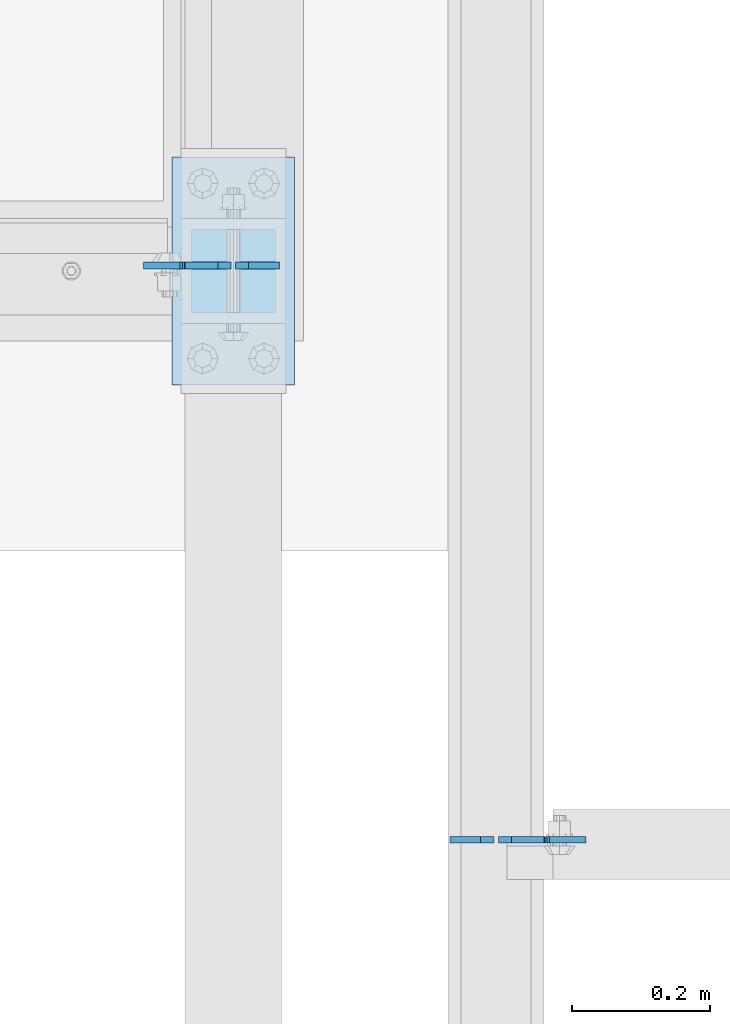
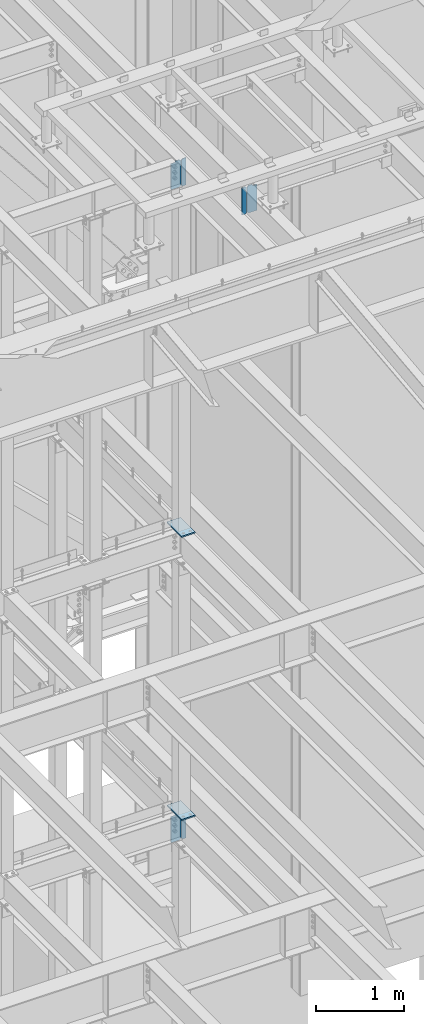
# One storey, part 1080 of 1179: 8 plates, 5 elements without a shape of their own.
"""IFC2X3 building model written with IfcOpenShell, lengths in millimetres."""

from ifc_helpers import new_model, si_unit, frame, origin_with_axes, place, context, subcontext, project, spatial, faceted_brep, material, type_object, element, aggregate, save


model = new_model("IFC2X3")

# Units and contexts
model_context = context("Model", 3, precision=1e-05, world=origin_with_axes())
body_context = subcontext(model_context, "Body", "Model", "MODEL_VIEW")
ifc_project = project(units=[si_unit("LENGTHUNIT", "METRE", prefix="MILLI"), si_unit("AREAUNIT", "SQUARE_METRE"), si_unit("VOLUMEUNIT", "CUBIC_METRE"), si_unit("MASSUNIT", "GRAM", prefix="KILO"), si_unit("TIMEUNIT", "SECOND"), si_unit("PLANEANGLEUNIT", "RADIAN"), si_unit("SOLIDANGLEUNIT", "STERADIAN"), si_unit("THERMODYNAMICTEMPERATUREUNIT", "DEGREE_CELSIUS"), si_unit("LUMINOUSINTENSITYUNIT", "LUMEN")], contexts=[model_context])

# Site, building, storey
site_placement = place(None, origin_with_axes())
site = spatial("IfcSite", under=ifc_project, at=site_placement, CompositionType="ELEMENT")
building_placement = place(site_placement, origin_with_axes())
building = spatial("IfcBuilding", under=site, at=building_placement, Name="Undefined", CompositionType="ELEMENT")
storey_placement = place(building_placement, origin_with_axes())
storey = spatial("IfcBuildingStorey", under=building, at=storey_placement, Name="Undefined", CompositionType="ELEMENT", Elevation=0.0)

# Assembly, plate
assembly_1_placement = place(storey_placement, origin_with_axes())
assembly_1 = element("IfcElementAssembly", 1, at=assembly_1_placement, inside=storey, Name="BEAM", AssemblyPlace="NOTDEFINED", PredefinedType="RIGID_FRAME")
ifc_material = material(Name="STEEL/A36")
plate_type_1 = type_object("IfcPlateType", PredefinedType="NOTDEFINED")
plate_1_placement = place(assembly_1_placement, frame((14182.7251120946, 36647.4380284119, 3711.575), z_axis=(0.0, 0.0, 1.0), x_axis=(-1.0, 0.0, 0.0)))
plate_1 = element("IfcPlate", 2, at=plate_1_placement, type_object=plate_type_1, material=ifc_material, Name="PLATE", context=body_context, shape_type="Brep", body=[
    faceted_brep([(66.6743865212811, -4.76249999999709, 377.825), (66.6745864763507, -4.76249999999709, 371.474599924168), (66.6745876193563, 4.76249999999709, 371.474599924203), (66.6743876643031, 4.76249999999709, 377.825), (67.6414311678836, -4.76249999999709, 366.614643208318), (67.6414323108893, 4.76249999999709, 366.614643208353), (70.3944716748138, -4.76249999999709, 362.494602443389), (70.3944728178176, 4.76249999999709, 362.494602443423), (74.5145991226364, -4.76249999999709, 359.741691665477), (74.514600265642, 4.76249999999709, 359.741691665511), (79.3745862790947, -4.76249999999709, 358.774999999796), (79.3745874221004, 4.76249999999709, 358.774999999831), (127.000000004868, -4.76249999999709, 358.774999992755), (127.0, 4.76249999999709, 358.774999992755), (0.0, -4.76249999999709, 358.775000762939), (19.0499992370605, -4.76249999999709, 377.825), (19.0499992370605, 4.76249999999709, 377.825), (0.0, 4.76249999999709, 358.775000762939), (0.0, -4.76250000000073, 19.0499992370605), (0.0, 4.76250000000073, 19.0499992370605), (19.0499992370605, -4.76250000000073, 0.0), (19.0499992370605, 4.76250000000073, 0.0), (127.0, -4.76250000000073, 0.0), (127.0, 4.76250000000073, 0.0)], [[[0, 1, 2, 3]], [[4, 5, 2, 1]], [[6, 7, 5, 4]], [[8, 9, 7, 6]], [[10, 11, 9, 8]], [[12, 13, 11, 10]], [[14, 15, 16, 17]], [[18, 14, 17, 19]], [[20, 18, 19, 21]], [[22, 20, 21, 23]], [[8, 6, 4, 1, 0, 15, 14, 18, 20, 22, 12, 10]], [[16, 15, 0, 3]], [[23, 21, 19, 17, 16, 3, 2, 5, 7, 9, 11, 13]], [[22, 23, 13, 12]]]),
])

assembly_2_placement = place(storey_placement, origin_with_axes())
assembly_2 = element("IfcElementAssembly", 3, at=assembly_2_placement, inside=storey, Name="BEAM", AssemblyPlace="NOTDEFINED", PredefinedType="RIGID_FRAME")
plate_2_placement = place(assembly_2_placement, frame((14570.075, 35814.7942499161, 12728.575), z_axis=(0.0, 0.0, 1.0), x_axis=(1.0, 0.0, 0.0)))
plate_2 = element("IfcPlate", 4, at=plate_2_placement, type_object=plate_type_1, material=ifc_material, Name="PLATE", context=body_context, shape_type="Brep", body=[
    faceted_brep([(66.6749998164378, -4.76249999999709, 377.825), (66.6749999434469, -4.76249999999709, 371.474999553748), (66.6749999434469, 4.76249999999709, 371.474999553748), (66.6749998164378, 4.76249999999709, 377.825), (67.641729938794, -4.76249999999709, 366.614920114053), (67.641729938794, 4.76249999999709, 366.614920114053), (70.394743855788, -4.76249999999709, 362.494743732281), (70.394743855788, 4.76249999999709, 362.494743732281), (74.5149202922948, -4.76249999999709, 359.741729897201), (74.5149202922948, 4.76249999999709, 359.741729897201), (79.3749997512095, -4.76249999999709, 358.774999998475), (79.3749997512095, 4.76249999999709, 358.774999998475), (127.000000004868, -4.76249999999709, 358.774999992755), (127.0, 4.76249999999709, 358.774999992755), (0.0, -4.76249999999709, 358.775000762939), (19.0499992370605, -4.76249999999709, 377.825), (19.0499992370605, 4.76249999999709, 377.825), (0.0, 4.76249999999709, 358.775000762939), (0.0, -4.76250000000073, 19.0499992370605), (0.0, 4.76250000000073, 19.0499992370605), (19.0499992370605, -4.76250000000073, 0.0), (19.0499992370605, 4.76250000000073, 0.0), (127.0, -4.76250000000073, 0.0), (127.0, 4.76250000000073, 0.0)], [[[0, 1, 2, 3]], [[4, 5, 2, 1]], [[6, 7, 5, 4]], [[8, 9, 7, 6]], [[10, 11, 9, 8]], [[12, 13, 11, 10]], [[14, 15, 16, 17]], [[18, 14, 17, 19]], [[20, 18, 19, 21]], [[22, 20, 21, 23]], [[8, 6, 4, 1, 0, 15, 14, 18, 20, 22, 12, 10]], [[16, 15, 0, 3]], [[23, 21, 19, 17, 16, 3, 2, 5, 7, 9, 11, 13]], [[22, 23, 13, 12]]]),
])

assembly_3_placement = place(storey_placement, origin_with_axes())
assembly_3 = element("IfcElementAssembly", 5, at=assembly_3_placement, inside=storey, Name="BEAM", AssemblyPlace="NOTDEFINED", PredefinedType="RIGID_FRAME")
plate_3_placement = place(assembly_3_placement, frame((14182.725, 36647.4381185476, 12728.575), z_axis=(0.0, 0.0, 1.0), x_axis=(-1.0, 0.0, 0.0)))
plate_3 = element("IfcPlate", 6, at=plate_3_placement, type_object=plate_type_1, material=ifc_material, Name="PLATE", context=body_context, shape_type="Brep", body=[
    faceted_brep([(66.6749998164378, -4.76249999999709, 377.825), (66.6749999434469, -4.76249999999709, 371.474999553748), (66.6749999434469, 4.76249999999709, 371.474999553748), (66.6749998164378, 4.76249999999709, 377.825), (67.641729938794, -4.76249999999709, 366.614920114053), (67.641729938794, 4.76249999999709, 366.614920114053), (70.394743855788, -4.76249999999709, 362.494743732281), (70.394743855788, 4.76249999999709, 362.494743732281), (74.5149202922948, -4.76249999999709, 359.741729897201), (74.5149202922948, 4.76249999999709, 359.741729897201), (79.3749997512095, -4.76249999999709, 358.774999998475), (79.3749997512095, 4.76249999999709, 358.774999998475), (127.000000004868, -4.76249999999709, 358.774999992755), (127.0, 4.76249999999709, 358.774999992755), (0.0, -4.76249999999709, 358.775000762939), (19.0499992370605, -4.76249999999709, 377.825), (19.0499992370605, 4.76249999999709, 377.825), (0.0, 4.76249999999709, 358.775000762939), (0.0, -4.76250000000073, 19.0499992370605), (0.0, 4.76250000000073, 19.0499992370605), (19.0499992370605, -4.76250000000073, 0.0), (19.0499992370605, 4.76250000000073, 0.0), (127.0, -4.76250000000073, 0.0), (127.0, 4.76250000000073, 0.0)], [[[0, 1, 2, 3]], [[4, 5, 2, 1]], [[6, 7, 5, 4]], [[8, 9, 7, 6]], [[10, 11, 9, 8]], [[12, 13, 11, 10]], [[14, 15, 16, 17]], [[18, 14, 17, 19]], [[20, 18, 19, 21]], [[22, 20, 21, 23]], [[8, 6, 4, 1, 0, 15, 14, 18, 20, 22, 12, 10]], [[16, 15, 0, 3]], [[23, 21, 19, 17, 16, 3, 2, 5, 7, 9, 11, 13]], [[22, 23, 13, 12]]]),
])

assembly_4_placement = place(storey_placement, origin_with_axes())
assembly_4 = element("IfcElementAssembly", 7, at=assembly_4_placement, inside=storey, Name="COLUMN", AssemblyPlace="NOTDEFINED", PredefinedType="RIGID_FRAME")
plate_type_2 = type_object("IfcPlateType", PredefinedType="NOTDEFINED")
plate_4_placement = place(assembly_4_placement, frame((14097.0, 36474.4, 8023.225), z_axis=(0.0, 1.0, 0.0), x_axis=(1.0, 0.0, 0.0)))
plate_4 = element("IfcPlate", 8, at=plate_4_placement, type_object=plate_type_2, material=ifc_material, Name="PLATE", context=body_context, shape_type="Brep", body=[
    faceted_brep([(0.0, -9.52499999999964, 0.0), (0.0, -9.52499999999964, 330.200012207031), (0.0, 9.52499999999964, 330.200012207031), (0.0, 9.52499999999964, 0.0), (177.800003051758, -9.52499999999964, 330.200012207031), (177.800003051758, 9.52499999999964, 330.200012207031), (177.800003051758, -9.52499999999964, 0.0), (177.800003051758, 9.52499999999964, 0.0)], [[[0, 1, 2, 3]], [[1, 4, 5, 2]], [[4, 6, 7, 5]], [[6, 0, 3, 7]], [[5, 7, 3, 2]], [[6, 4, 1, 0]]]),
])
aggregate(assembly_4, [plate_4])

assembly_5_placement = place(storey_placement, origin_with_axes())
assembly_5 = element("IfcElementAssembly", 9, at=assembly_5_placement, inside=storey, Name="COLUMN", AssemblyPlace="NOTDEFINED", PredefinedType="RIGID_FRAME")
plate_5_placement = place(assembly_5_placement, frame((14096.9999999996, 36474.4, 4111.625), z_axis=(0.0, 1.0, 0.0), x_axis=(1.0, 0.0, 0.0)))
plate_5 = element("IfcPlate", 10, at=plate_5_placement, type_object=plate_type_2, material=ifc_material, Name="PLATE", context=body_context, shape_type="Brep", body=[
    faceted_brep([(0.0, -9.52499999999964, 0.0), (0.0, -9.52499999999964, 330.200012207031), (0.0, 9.52499999999964, 330.200012207031), (0.0, 9.52499999999964, 0.0), (177.800003051758, -9.52499999999964, 330.200012207031), (177.800003051758, 9.52499999999964, 330.200012207031), (177.800003051758, -9.52499999999964, 0.0), (177.800003051758, 9.52499999999964, 0.0)], [[[0, 1, 2, 3]], [[1, 4, 5, 2]], [[4, 6, 7, 5]], [[6, 0, 3, 7]], [[5, 7, 3, 2]], [[6, 4, 1, 0]]]),
])
aggregate(assembly_5, [plate_5])

# Plate
plate_type_3 = type_object("IfcPlateType", PredefinedType="NOTDEFINED")
plate_6_placement = place(assembly_1_placement, frame((14189.0751122137, 36647.4380285668, 3711.575), z_axis=(0.0, 0.0, 1.0), x_axis=(1.0, 0.0, 0.0)))
plate_6 = element("IfcPlate", 11, at=plate_6_placement, type_object=plate_type_3, material=ifc_material, Name="PLATE", context=body_context, shape_type="Brep", body=[
    faceted_brep([(0.0, -4.76250000000073, 19.0499992370605), (0.0, -4.76249999999709, 358.775000762939), (0.0, 4.76249999999709, 358.775000762939), (0.0, 4.76250000000073, 19.0499992370605), (19.0499992370605, -4.76249999999709, 377.825), (19.0499992370605, 4.76249999999709, 377.825), (63.5, -4.76250000000073, 377.825012207031), (63.5, 4.76250000000073, 377.825012207031), (63.5, -4.76250000000073, 0.0), (63.5, 4.76250000000073, 0.0), (19.0499992370605, -4.76250000000073, 0.0), (19.0499992370605, 4.76250000000073, 0.0)], [[[0, 1, 2, 3]], [[1, 4, 5, 2]], [[4, 6, 7, 5]], [[6, 8, 9, 7]], [[8, 10, 11, 9]], [[10, 0, 3, 11]], [[5, 7, 9, 11, 3, 2]], [[10, 8, 6, 4, 1, 0]]]),
])

aggregate(assembly_1, [plate_6, plate_1])

plate_7_placement = place(assembly_2_placement, frame((14563.725, 35814.7942499161, 12728.575), z_axis=(0.0, 0.0, 1.0), x_axis=(-1.0, 0.0, 0.0)))
plate_7 = element("IfcPlate", 12, at=plate_7_placement, type_object=plate_type_3, material=ifc_material, Name="PLATE", context=body_context, shape_type="Brep", body=[
    faceted_brep([(0.0, -4.76250000000073, 19.0499992370605), (0.0, -4.76249999999709, 358.775000762939), (0.0, 4.76249999999709, 358.775000762939), (0.0, 4.76250000000073, 19.0499992370605), (19.0499992370605, -4.76249999999709, 377.825), (19.0499992370605, 4.76249999999709, 377.825), (63.5, -4.76250000000073, 377.825012207031), (63.5, 4.76250000000073, 377.825012207031), (63.5, -4.76250000000073, 0.0), (63.5, 4.76250000000073, 0.0), (19.0499992370605, -4.76250000000073, 0.0), (19.0499992370605, 4.76250000000073, 0.0)], [[[0, 1, 2, 3]], [[1, 4, 5, 2]], [[4, 6, 7, 5]], [[6, 8, 9, 7]], [[8, 10, 11, 9]], [[10, 0, 3, 11]], [[5, 7, 9, 11, 3, 2]], [[10, 8, 6, 4, 1, 0]]]),
])

aggregate(assembly_2, [plate_7, plate_2])

plate_8_placement = place(assembly_3_placement, frame((14189.075, 36647.4381185476, 12728.575), z_axis=(0.0, 0.0, 1.0), x_axis=(1.0, 0.0, 0.0)))
plate_8 = element("IfcPlate", 13, at=plate_8_placement, type_object=plate_type_3, material=ifc_material, Name="PLATE", context=body_context, shape_type="Brep", body=[
    faceted_brep([(0.0, -4.76250000000073, 19.0499992370605), (0.0, -4.76249999999709, 358.775000762939), (0.0, 4.76249999999709, 358.775000762939), (0.0, 4.76250000000073, 19.0499992370605), (19.0499992370605, -4.76249999999709, 377.825), (19.0499992370605, 4.76249999999709, 377.825), (63.5, -4.76250000000073, 377.825012207031), (63.5, 4.76250000000073, 377.825012207031), (63.5, -4.76250000000073, 0.0), (63.5, 4.76250000000073, 0.0), (19.0499992370605, -4.76250000000073, 0.0), (19.0499992370605, 4.76250000000073, 0.0)], [[[0, 1, 2, 3]], [[1, 4, 5, 2]], [[4, 6, 7, 5]], [[6, 8, 9, 7]], [[8, 10, 11, 9]], [[10, 0, 3, 11]], [[5, 7, 9, 11, 3, 2]], [[10, 8, 6, 4, 1, 0]]]),
])

aggregate(assembly_3, [plate_8, plate_3])

save(model, "model.ifc")
